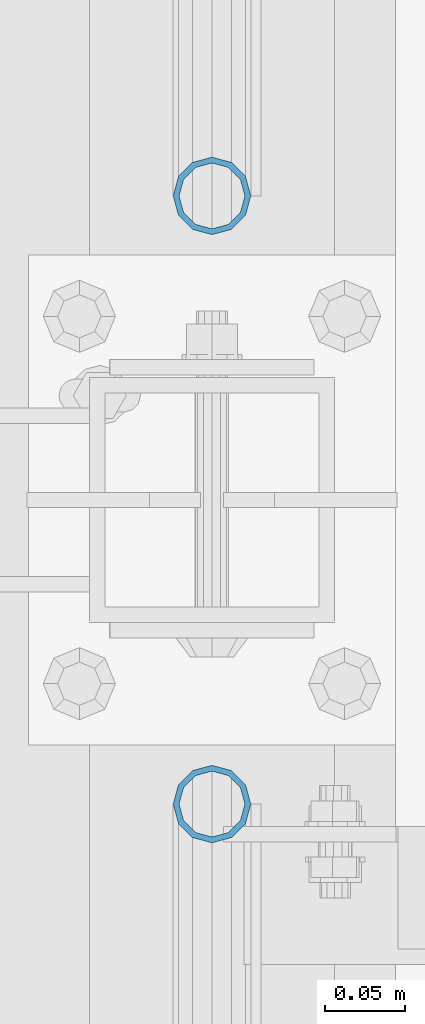
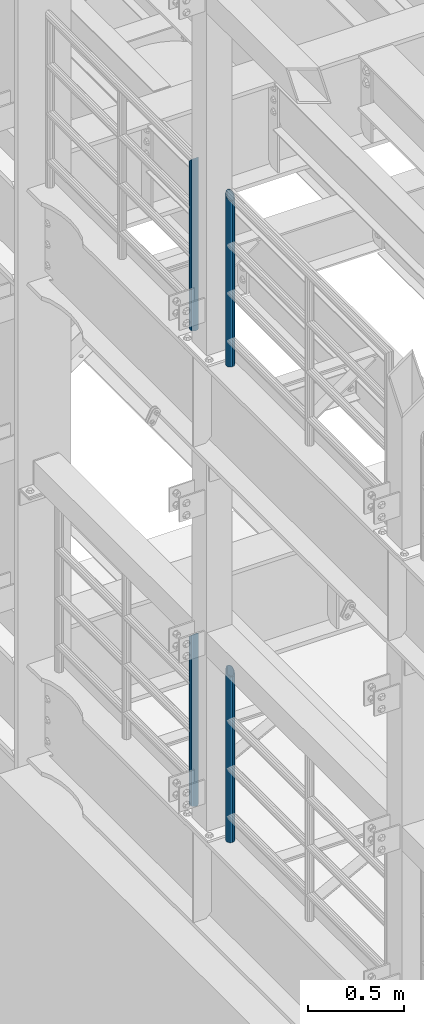
# One storey, part 702 of 1876: 4 columns, 4 elements without a shape of their own.
"""IFC2X3 building model written with IfcOpenShell, lengths in millimetres."""

import ifcopenshell
import ifcopenshell.guid

model = None  # the IFC model being written
_history = None  # IfcOwnerHistory: only IFC2X3 demands one
_inside = {}  # id of a spatial element -> (the spatial element, [elements in it])
_under = {}  # id of a project, library or spatial element -> (it, [spatial elements below it])
_declared = {}  # id of a project -> (the project, [libraries it declares])
_typed = {}  # id of a type object -> (the type object, [elements of that type])
_made_of = {}  # id of a material, layer set ... -> (it, [elements and type objects made of it])


def new_model(schema):
    """Start an empty IFC model of exactly this schema.

    Asked for "IFC4X3", IfcOpenShell would pick the latest addendum, in which some entities
    have other attributes; the version numbers below select the first issue.
    IFC2X3 requires an IfcOwnerHistory on every rooted entity: one is made here for all.
    """
    global model, _history
    if schema == "IFC4X3":
        model = ifcopenshell.file(schema_version=(4, 3, 0, 0))
    else:
        model = ifcopenshell.file(schema=schema)
    _inside.clear()
    _under.clear()
    _declared.clear()
    _typed.clear()
    _made_of.clear()
    _history = None
    if model.schema == "IFC2X3":
        org = make("IfcOrganization", Name="unknown")
        user = make(
            "IfcPersonAndOrganization",
            ThePerson=make("IfcPerson", FamilyName="unknown"),
            TheOrganization=org,
        )
        app = make(
            "IfcApplication",
            ApplicationDeveloper=org,
            Version="unknown",
            ApplicationFullName="unknown",
            ApplicationIdentifier="unknown",
        )
        _history = make(
            "IfcOwnerHistory",
            OwningUser=user,
            OwningApplication=app,
            ChangeAction="ADDED",
            CreationDate=0,
        )
    return model


def make(cls, **values):
    """One entity of the class cls with the attributes given. An attribute that is None is left unset."""
    return model.create_entity(
        cls, **{name: value for name, value in values.items() if value is not None}
    )


def rooted(cls, **values):
    """An entity with a GlobalId (a new one), such as an element, a storey or a relation."""
    return make(cls, GlobalId=ifcopenshell.guid.new(), OwnerHistory=_history, **values)


def si_unit(unit_type, name, prefix=None):
    """IfcSIUnit, for example si_unit("LENGTHUNIT", "METRE", prefix="MILLI")."""
    return make("IfcSIUnit", UnitType=unit_type, Prefix=prefix, Name=name)


def assignment(units):
    """IfcUnitAssignment: the units of a project."""
    return None if units is None else make("IfcUnitAssignment", Units=units)


def point(xyz):
    """IfcCartesianPoint."""
    return None if xyz is None else make("IfcCartesianPoint", Coordinates=xyz)


def direction(xyz):
    """IfcDirection."""
    return None if xyz is None else make("IfcDirection", DirectionRatios=xyz)


def frame(location, z_axis=None, x_axis=None):
    """IfcAxis2Placement3D, a coordinate frame: its origin and axes. An axis left out is left unset."""
    return make(
        "IfcAxis2Placement3D",
        Location=point(location),
        Axis=direction(z_axis),
        RefDirection=direction(x_axis),
    )


def origin_with_axes():
    """The frame at (0, 0, 0) with the z axis (0, 0, 1) and the x axis (1, 0, 0) written out."""
    return frame((0.0, 0.0, 0.0), z_axis=(0.0, 0.0, 1.0), x_axis=(1.0, 0.0, 0.0))


def place(relative_to, where):
    """IfcLocalPlacement: puts the frame where relative to a parent placement (None: the world)."""
    return make(
        "IfcLocalPlacement", PlacementRelTo=relative_to, RelativePlacement=where
    )


def context(
    kind, dimensions, precision=None, world=None, true_north=None, identifier=None
):
    """IfcGeometricRepresentationContext, for example the 3D "Model" context."""
    return make(
        "IfcGeometricRepresentationContext",
        ContextIdentifier=identifier,
        ContextType=kind,
        CoordinateSpaceDimension=dimensions,
        Precision=precision,
        WorldCoordinateSystem=world,
        TrueNorth=true_north,
    )


def subcontext(parent, identifier, kind, view, scale=None):
    """IfcGeometricRepresentationSubContext, for example "Body" below "Model"."""
    return make(
        "IfcGeometricRepresentationSubContext",
        ContextIdentifier=identifier,
        ContextType=kind,
        ParentContext=parent,
        TargetScale=scale,
        TargetView=view,
    )


def project(units=None, contexts=None):
    """IfcProject with its units and contexts."""
    return rooted(
        "IfcProject",
        Name="project",
        RepresentationContexts=contexts,
        UnitsInContext=assignment(units),
    )


def spatial(cls, under=None, at=None, **own):
    """A site, building, storey or space (cls), placed at a placement, below another one or the project."""
    s = rooted(cls, ObjectPlacement=at, **own)
    if under is not None:
        _under.setdefault(under.id(), (under, []))[1].append(s)
    return s


def faces_of(points, faces, orient=None, outer=None):
    """IfcFace entities. A face is a list of loops; a loop is a list of indices into points, from 0.

    orient and outer hold one flag for each loop. By default every Orientation is true, the
    first loop of a face is its IfcFaceOuterBound and the others are IfcFaceBound.
    """
    made = []
    for i, loops in enumerate(faces):
        bounds = []
        for j, loop in enumerate(loops):
            is_outer = j == 0 if outer is None else outer[i][j]
            bounds.append(
                make(
                    "IfcFaceOuterBound" if is_outer else "IfcFaceBound",
                    Bound=make("IfcPolyLoop", Polygon=[points[k] for k in loop]),
                    Orientation=True if orient is None else orient[i][j],
                )
            )
        made.append(make("IfcFace", Bounds=bounds))
    return made


def faceted_brep(points, faces, orient=None, outer=None, voids=None):
    """IfcFacetedBrep: a solid bounded by flat faces; with voids (closed shells), ...WithVoids."""
    shared = [point(p) for p in points]
    hull = make("IfcClosedShell", CfsFaces=faces_of(shared, faces, orient, outer))
    if voids is None:
        return make("IfcFacetedBrep", Outer=hull)
    return make(
        "IfcFacetedBrepWithVoids",
        Outer=hull,
        Voids=[
            make(cls, CfsFaces=faces_of(shared, fs, o, b)) for cls, fs, o, b in voids
        ],
    )


def shape(context_of_items, identifier, shape_type, items):
    """IfcShapeRepresentation: the items that make up one representation, for example the "Body"."""
    return make(
        "IfcShapeRepresentation",
        ContextOfItems=context_of_items,
        RepresentationIdentifier=identifier,
        RepresentationType=shape_type,
        Items=items,
    )


def material(Name=None, Category=None):
    """IfcMaterial."""
    return make("IfcMaterial", Name=Name, Category=Category)


def made_of(thing, what):
    """Note that an element or type object is made of a material, layer set ...; save() writes the relation."""
    if what is not None:
        _made_of.setdefault(what.id(), (what, []))[1].append(thing)
    return thing


def type_object(cls, material=None, **own):
    """A type object (cls), such as IfcWallType, which elements share."""
    return made_of(rooted(cls, **own), material)


def element(
    cls,
    number,
    at=None,
    inside=None,
    cuts=None,
    type_object=None,
    material=None,
    context=None,
    identifier="Body",
    shape_type=None,
    held_by="IfcProductDefinitionShape",
    body=None,
    shapes=None,
    **own,
):
    """One element of the class cls, such as IfcWall. Its Tag is "e" and its number.

    at: its placement. inside: the storey or other place that contains it. cuts: it is an
    opening in that element (IfcRelVoidsElement). A single representation is given by context,
    identifier, shape_type and body (its items); several are given by shapes. held_by: the class
    of the entity that holds the representations. save() writes the other relations.
    """
    e = rooted(cls, Tag="e%d" % number, ObjectPlacement=at, **own)
    if body is not None:
        shapes = [shape(context, identifier, shape_type, body)]
    if shapes is not None:
        e.Representation = make(held_by, Representations=shapes)
    if inside is not None:
        _inside.setdefault(inside.id(), (inside, []))[1].append(e)
    if cuts is not None:
        rooted(
            "IfcRelVoidsElement", RelatingBuildingElement=cuts, RelatedOpeningElement=e
        )
    if type_object is not None:
        _typed.setdefault(type_object.id(), (type_object, []))[1].append(e)
    return made_of(e, material)


def aggregate(whole, parts):
    """IfcRelAggregates: a whole, such as a stair, and the parts it consists of."""
    return rooted("IfcRelAggregates", RelatingObject=whole, RelatedObjects=parts)


def save(model, path):
    """Write the relations noted so far, then the file.

    IfcRelAggregates (storeys below a building ...), IfcRelContainedInSpatialStructure (elements
    in a storey), IfcRelDefinesByType, IfcRelAssociatesMaterial and IfcRelDeclares: one each for
    every whole, place, type object, material and project.
    """
    for whole, parts in _under.values():
        aggregate(whole, parts)
    for where, things in _inside.values():
        rooted(
            "IfcRelContainedInSpatialStructure",
            RelatedElements=things,
            RelatingStructure=where,
        )
    for kind, things in _typed.values():
        rooted("IfcRelDefinesByType", RelatedObjects=things, RelatingType=kind)
    for what, things in _made_of.values():
        rooted("IfcRelAssociatesMaterial", RelatedObjects=things, RelatingMaterial=what)
    for by, libraries in _declared.values():
        rooted("IfcRelDeclares", RelatingContext=by, RelatedDefinitions=libraries)
    model.write(path)


model = new_model("IFC2X3")

# Units and contexts
model_context = context("Model", 3, precision=1e-05, world=origin_with_axes())
body_context = subcontext(model_context, "Body", "Model", "MODEL_VIEW")
ifc_project = project(units=[si_unit("LENGTHUNIT", "METRE", prefix="MILLI"), si_unit("AREAUNIT", "SQUARE_METRE"), si_unit("VOLUMEUNIT", "CUBIC_METRE"), si_unit("MASSUNIT", "GRAM", prefix="KILO"), si_unit("TIMEUNIT", "SECOND"), si_unit("PLANEANGLEUNIT", "RADIAN"), si_unit("SOLIDANGLEUNIT", "STERADIAN"), si_unit("THERMODYNAMICTEMPERATUREUNIT", "DEGREE_CELSIUS"), si_unit("LUMINOUSINTENSITYUNIT", "LUMEN")], contexts=[model_context])

# Site, building, storey
site_placement = place(None, origin_with_axes())
site = spatial("IfcSite", under=ifc_project, at=site_placement, CompositionType="ELEMENT")
building_placement = place(site_placement, origin_with_axes())
building = spatial("IfcBuilding", under=site, at=building_placement, Name="Undefined", CompositionType="ELEMENT")
storey_placement = place(building_placement, origin_with_axes())
storey = spatial("IfcBuildingStorey", under=building, at=storey_placement, Name="Undefined", CompositionType="ELEMENT", Elevation=0.0)

# Assembly, column
assembly_1_placement = place(storey_placement, origin_with_axes())
assembly_1 = element("IfcElementAssembly", 1, at=assembly_1_placement, inside=storey, Name="RAIL", AssemblyPlace="NOTDEFINED", PredefinedType="RIGID_FRAME")
ifc_material = material()
column_type = type_object("IfcColumnType", Name="PIPE1-1/2SCH40", PredefinedType="NOTDEFINED")
column_1_placement = place(assembly_1_placement, frame((-1.81898940354586e-12, 5777.23, 8153.4), z_axis=(0.0, 1.0, 0.0), x_axis=(0.0, 0.0, 1.0)))
column_1 = element("IfcColumn", 2, at=column_1_placement, type_object=column_type, material=ifc_material, Name="POST", ObjectType="PIPE1-1/2SCH40", context=body_context, shape_type="Brep", body=[
    faceted_brep([(0.0, -20.4469999999999, 0.0), (0.0, -17.7076214311803, 10.2235000000001), (1066.1015, -17.7076214311803, 10.2235000000001), (1076.325, -20.4469999999999, 0.0), (0.0, -10.2235000000001, 17.7076214311801), (1058.61737856882, -10.2235000000001, 17.7076214311801), (-1.45519152283669e-11, 0.0, 20.4470000000001), (1055.878, 0.0, 20.4470000000001), (0.0, 10.2235000000001, 17.7076214311801), (1058.61737856882, 10.2235000000001, 17.7076214311801), (0.0, 17.7076214311803, 10.2235000000001), (1066.1015, 17.7076214311803, 10.2235000000001), (0.0, 20.4469999999999, 0.0), (1076.325, 20.4469999999999, 0.0), (0.0, 17.7076214311803, -10.2235000000001), (1086.5485, 17.7076214311803, -10.2235000000001), (0.0, 10.2235000000001, -17.7076214311801), (1094.03262143118, 10.2235000000001, -17.7076214311801), (-1.45519152283669e-11, 0.0, -20.4470000000001), (1096.772, 0.0, -20.4470000000001), (0.0, -10.2235000000001, -17.7076214311801), (1094.03262143118, -10.2235000000001, -17.7076214311801), (0.0, -17.7076214311803, -10.2235000000001), (1086.5485, -17.7076214311803, -10.2235000000001), (0.0, -24.1299999999992, 0.0), (0.0, -20.8971929933184, -12.0649999999996), (1088.39, -20.8971929933184, -12.0649999999996), (1076.325, -24.1300000000001, 0.0), (0.0, -12.0650000000001, -20.8971929933186), (1097.22219299332, -12.0650000000001, -20.8971929933186), (-1.45519152283669e-11, 0.0, -24.130000000001), (1100.455, 0.0, -24.1300000000001), (0.0, 12.0650000000001, -20.8971929933186), (1097.22219299332, 12.0650000000001, -20.8971929933186), (0.0, 20.8971929933184, -12.0649999999996), (1088.39, 20.8971929933184, -12.0649999999996), (0.0, 24.1299999999992, 0.0), (1076.325, 24.1300000000001, 0.0), (0.0, 20.8971929933184, 12.0649999999996), (1064.26, 20.8971929933184, 12.0649999999996), (0.0, 12.0650000000001, 20.8971929933186), (1055.42780700668, 12.0650000000001, 20.8971929933186), (-1.45519152283669e-11, 0.0, 24.130000000001), (1052.195, 0.0, 24.1300000000001), (0.0, -12.0650000000001, 20.8971929933186), (1055.42780700668, -12.0650000000001, 20.8971929933186), (0.0, -20.8971929933184, 12.0649999999996), (1064.26, -20.8971929933184, 12.0649999999996)], [[[0, 1, 2, 3]], [[1, 4, 5, 2]], [[4, 6, 7, 5]], [[6, 8, 9, 7]], [[8, 10, 11, 9]], [[10, 12, 13, 11]], [[12, 14, 15, 13]], [[14, 16, 17, 15]], [[16, 18, 19, 17]], [[18, 20, 21, 19]], [[20, 22, 23, 21]], [[22, 0, 3, 23]], [[24, 25, 26, 27]], [[25, 28, 29, 26]], [[28, 30, 31, 29]], [[30, 32, 33, 31]], [[32, 34, 35, 33]], [[34, 36, 37, 35]], [[36, 38, 39, 37]], [[38, 40, 41, 39]], [[40, 42, 43, 41]], [[42, 44, 45, 43]], [[44, 46, 47, 45]], [[46, 24, 27, 47]], [[29, 31, 33, 35, 37, 39, 41, 43, 45, 47, 27, 26], [5, 7, 9, 11, 13, 15, 17, 19, 21, 23, 3, 2]], [[46, 44, 42, 40, 38, 36, 34, 32, 30, 28, 25, 24], [22, 20, 18, 16, 14, 12, 10, 8, 6, 4, 1, 0]]]),
])
aggregate(assembly_1, [column_1])

assembly_2_placement = place(storey_placement, origin_with_axes())
assembly_2 = element("IfcElementAssembly", 3, at=assembly_2_placement, inside=storey, Name="RAIL", AssemblyPlace="NOTDEFINED", PredefinedType="RIGID_FRAME")
column_2_placement = place(assembly_2_placement, frame((-1.81898940354586e-12, 5398.77, 8153.4), z_axis=(0.0, 1.0, 0.0), x_axis=(0.0, 0.0, 1.0)))
column_2 = element("IfcColumn", 4, at=column_2_placement, type_object=column_type, material=ifc_material, Name="POST", ObjectType="PIPE1-1/2SCH40", context=body_context, shape_type="Brep", body=[
    faceted_brep([(0.0, -20.4469999999999, 0.0), (0.0, -17.7076214311803, 10.2235000000001), (1086.54849999999, -17.7076214311801, 10.2235000000001), (1076.325, -20.4469999999999, 0.0), (0.0, -10.2235000000001, 17.7076214311801), (1094.03262143117, -10.2235000000001, 17.7076214311801), (-1.45519152283669e-11, 0.0, 20.4470000000001), (1096.77199999999, 0.0, 20.4470000000001), (0.0, 10.2235000000001, 17.7076214311801), (1094.03262143117, 10.2235000000001, 17.7076214311801), (0.0, 17.7076214311803, 10.2235000000001), (1086.54849999999, 17.7076214311801, 10.2235000000001), (0.0, 20.4469999999999, 0.0), (1076.325, 20.4469999999999, 0.0), (0.0, 17.7076214311803, -10.2235000000001), (1066.10149999999, 17.7076214311801, -10.2235000000001), (0.0, 10.2235000000001, -17.7076214311801), (1058.61737856881, 10.2235000000001, -17.7076214311801), (-1.45519152283669e-11, 0.0, -20.4470000000001), (1055.87799999999, 0.0, -20.4470000000001), (0.0, -10.2235000000001, -17.7076214311801), (1058.61737856881, -10.2235000000001, -17.7076214311801), (0.0, -17.7076214311803, -10.2235000000001), (1066.10149999999, -17.7076214311801, -10.2235000000001), (0.0, -24.1299999999992, 0.0), (0.0, -20.8971929933184, -12.0649999999996), (1064.25999999999, -20.8971929933186, -12.0649999999996), (1076.325, -24.1300000000001, 0.0), (0.0, -12.0650000000001, -20.8971929933186), (1055.42780700667, -12.0649999999996, -20.8971929933186), (-1.45519152283669e-11, 0.0, -24.130000000001), (1052.19499999999, 0.0, -24.1300000000001), (0.0, 12.0650000000001, -20.8971929933186), (1055.42780700667, 12.0649999999996, -20.8971929933186), (0.0, 20.8971929933184, -12.0649999999996), (1064.25999999999, 20.8971929933186, -12.0649999999996), (0.0, 24.1299999999992, 0.0), (1076.325, 24.1300000000001, 0.0), (0.0, 20.8971929933184, 12.0649999999996), (1088.38999999999, 20.8971929933186, 12.0649999999996), (0.0, 12.0650000000001, 20.8971929933186), (1097.22219299331, 12.0649999999996, 20.8971929933186), (-1.45519152283669e-11, 0.0, 24.130000000001), (1100.45499999999, 0.0, 24.1300000000001), (0.0, -12.0650000000001, 20.8971929933186), (1097.22219299331, -12.0649999999996, 20.8971929933186), (0.0, -20.8971929933184, 12.0649999999996), (1088.38999999999, -20.8971929933186, 12.0649999999996)], [[[0, 1, 2, 3]], [[1, 4, 5, 2]], [[4, 6, 7, 5]], [[6, 8, 9, 7]], [[8, 10, 11, 9]], [[10, 12, 13, 11]], [[12, 14, 15, 13]], [[14, 16, 17, 15]], [[16, 18, 19, 17]], [[18, 20, 21, 19]], [[20, 22, 23, 21]], [[22, 0, 3, 23]], [[24, 25, 26, 27]], [[25, 28, 29, 26]], [[28, 30, 31, 29]], [[30, 32, 33, 31]], [[32, 34, 35, 33]], [[34, 36, 37, 35]], [[36, 38, 39, 37]], [[38, 40, 41, 39]], [[40, 42, 43, 41]], [[42, 44, 45, 43]], [[44, 46, 47, 45]], [[46, 24, 27, 47]], [[29, 31, 33, 35, 37, 39, 41, 43, 45, 47, 27, 26], [5, 7, 9, 11, 13, 15, 17, 19, 21, 23, 3, 2]], [[46, 44, 42, 40, 38, 36, 34, 32, 30, 28, 25, 24], [22, 20, 18, 16, 14, 12, 10, 8, 6, 4, 1, 0]]]),
])
aggregate(assembly_2, [column_2])

assembly_3_placement = place(storey_placement, origin_with_axes())
assembly_3 = element("IfcElementAssembly", 5, at=assembly_3_placement, inside=storey, Name="RAIL", AssemblyPlace="NOTDEFINED", PredefinedType="RIGID_FRAME")
column_3_placement = place(assembly_3_placement, frame((-1.81898940354586e-12, 5777.23, 5130.8), z_axis=(0.0, 1.0, 0.0), x_axis=(0.0, 0.0, 1.0)))
column_3 = element("IfcColumn", 6, at=column_3_placement, type_object=column_type, material=ifc_material, Name="POST", ObjectType="PIPE1-1/2SCH40", context=body_context, shape_type="Brep", body=[
    faceted_brep([(0.0, -20.4469999999999, 0.0), (0.0, -17.7076214311803, 10.2235000000001), (1066.10158618498, -17.7076214311801, 10.2235000000001), (1076.325, -20.4469999999999, 0.0), (0.0, -10.2235000000001, 17.7076214311801), (1058.61752784562, -10.2235000000001, 17.7076214311801), (-1.45519152283669e-11, 0.0, 20.4470000000001), (1055.87817237002, 0.0, 20.4470000000001), (0.0, 10.2235000000001, 17.7076214311801), (1058.61752784562, 10.2235000000001, 17.7076214311801), (0.0, 17.7076214311803, 10.2235000000001), (1066.10158618498, 17.7076214311801, 10.2235000000001), (0.0, 20.4469999999999, 0.0), (1076.325, 20.4469999999999, 0.0), (0.0, 17.7076214311803, -10.2235000000001), (1086.54841381489, 17.7076214311801, -10.2235000000001), (0.0, 10.2235000000001, -17.7076214311801), (1094.03247215425, 10.2235000000001, -17.7076214311801), (-1.45519152283669e-11, 0.0, -20.4470000000001), (1096.77182762985, 0.0, -20.4470000000001), (0.0, -10.2235000000001, -17.7076214311801), (1094.03247215425, -10.2235000000001, -17.7076214311801), (0.0, -17.7076214311803, -10.2235000000001), (1086.54841381489, -17.7076214311801, -10.2235000000001), (0.0, -24.1299999999992, 0.0), (0.0, -20.8971929933184, -12.0649999999996), (1088.38989829088, -20.8971929933186, -12.0649999999996), (1076.325, -24.1300000000001, 0.0), (0.0, -12.0650000000001, -20.8971929933186), (1097.222016828, -12.0649999999996, -20.8971929933186), (-1.45519152283669e-11, 0.0, -24.130000000001), (1100.45479658183, 0.0, -24.1300000000001), (0.0, 12.0650000000001, -20.8971929933186), (1097.222016828, 12.0649999999996, -20.8971929933186), (0.0, 20.8971929933184, -12.0649999999996), (1088.38989829088, 20.8971929933186, -12.0649999999996), (0.0, 24.1299999999992, 0.0), (1076.325, 24.1300000000001, 0.0), (0.0, 20.8971929933184, 12.0649999999996), (1064.26010170542, 20.8971929933186, 12.0650000000001), (0.0, 12.0650000000001, 20.8971929933186), (1055.42798316718, 12.0649999999996, 20.8971929933186), (-1.45519152283669e-11, 0.0, 24.130000000001), (1052.19520341295, 0.0, 24.1300000000001), (0.0, -12.0650000000001, 20.8971929933186), (1055.42798316718, -12.0649999999996, 20.8971929933186), (0.0, -20.8971929933184, 12.0649999999996), (1064.26010170542, -20.8971929933186, 12.0650000000001)], [[[0, 1, 2, 3]], [[1, 4, 5, 2]], [[4, 6, 7, 5]], [[6, 8, 9, 7]], [[8, 10, 11, 9]], [[10, 12, 13, 11]], [[12, 14, 15, 13]], [[14, 16, 17, 15]], [[16, 18, 19, 17]], [[18, 20, 21, 19]], [[20, 22, 23, 21]], [[22, 0, 3, 23]], [[24, 25, 26, 27]], [[25, 28, 29, 26]], [[28, 30, 31, 29]], [[30, 32, 33, 31]], [[32, 34, 35, 33]], [[34, 36, 37, 35]], [[36, 38, 39, 37]], [[38, 40, 41, 39]], [[40, 42, 43, 41]], [[42, 44, 45, 43]], [[44, 46, 47, 45]], [[46, 24, 27, 47]], [[29, 31, 33, 35, 37, 39, 41, 43, 45, 47, 27, 26], [5, 7, 9, 11, 13, 15, 17, 19, 21, 23, 3, 2]], [[46, 44, 42, 40, 38, 36, 34, 32, 30, 28, 25, 24], [22, 20, 18, 16, 14, 12, 10, 8, 6, 4, 1, 0]]]),
])
aggregate(assembly_3, [column_3])

assembly_4_placement = place(storey_placement, origin_with_axes())
assembly_4 = element("IfcElementAssembly", 7, at=assembly_4_placement, inside=storey, Name="RAIL", AssemblyPlace="NOTDEFINED", PredefinedType="RIGID_FRAME")
column_4_placement = place(assembly_4_placement, frame((-1.81898940354586e-12, 5398.77, 5130.8), z_axis=(0.0, 1.0, 0.0), x_axis=(0.0, 0.0, 1.0)))
column_4 = element("IfcColumn", 8, at=column_4_placement, type_object=column_type, material=ifc_material, Name="POST", ObjectType="PIPE1-1/2SCH40", context=body_context, shape_type="Brep", body=[
    faceted_brep([(0.0, -20.4469999999999, 0.0), (0.0, -17.7076214311803, 10.2235000000001), (1086.54849999999, -17.7076214311801, 10.2235000000001), (1076.325, -20.4469999999999, 0.0), (0.0, -10.2235000000001, 17.7076214311801), (1094.03262143117, -10.2235000000001, 17.7076214311801), (-1.45519152283669e-11, 0.0, 20.4470000000001), (1096.77199999999, 0.0, 20.4470000000001), (0.0, 10.2235000000001, 17.7076214311801), (1094.03262143117, 10.2235000000001, 17.7076214311801), (0.0, 17.7076214311803, 10.2235000000001), (1086.54849999999, 17.7076214311801, 10.2235000000001), (0.0, 20.4469999999999, 0.0), (1076.325, 20.4469999999999, 0.0), (0.0, 17.7076214311803, -10.2235000000001), (1066.10149999999, 17.7076214311801, -10.2235000000001), (0.0, 10.2235000000001, -17.7076214311801), (1058.61737856881, 10.2235000000001, -17.7076214311801), (-1.45519152283669e-11, 0.0, -20.4470000000001), (1055.87799999999, 0.0, -20.4470000000001), (0.0, -10.2235000000001, -17.7076214311801), (1058.61737856881, -10.2235000000001, -17.7076214311801), (0.0, -17.7076214311803, -10.2235000000001), (1066.10149999999, -17.7076214311801, -10.2235000000001), (0.0, -24.1299999999992, 0.0), (0.0, -20.8971929933184, -12.0649999999996), (1064.25999999999, -20.8971929933186, -12.0649999999996), (1076.325, -24.1300000000001, 0.0), (0.0, -12.0650000000001, -20.8971929933186), (1055.42780700667, -12.0649999999996, -20.8971929933186), (-1.45519152283669e-11, 0.0, -24.130000000001), (1052.19499999999, 0.0, -24.1300000000001), (0.0, 12.0650000000001, -20.8971929933186), (1055.42780700667, 12.0649999999996, -20.8971929933186), (0.0, 20.8971929933184, -12.0649999999996), (1064.25999999999, 20.8971929933186, -12.0649999999996), (0.0, 24.1299999999992, 0.0), (1076.325, 24.1300000000001, 0.0), (0.0, 20.8971929933184, 12.0649999999996), (1088.38999999999, 20.8971929933186, 12.0649999999996), (0.0, 12.0650000000001, 20.8971929933186), (1097.22219299331, 12.0649999999996, 20.8971929933186), (-1.45519152283669e-11, 0.0, 24.130000000001), (1100.45499999999, 0.0, 24.1300000000001), (0.0, -12.0650000000001, 20.8971929933186), (1097.22219299331, -12.0649999999996, 20.8971929933186), (0.0, -20.8971929933184, 12.0649999999996), (1088.38999999999, -20.8971929933186, 12.0649999999996)], [[[0, 1, 2, 3]], [[1, 4, 5, 2]], [[4, 6, 7, 5]], [[6, 8, 9, 7]], [[8, 10, 11, 9]], [[10, 12, 13, 11]], [[12, 14, 15, 13]], [[14, 16, 17, 15]], [[16, 18, 19, 17]], [[18, 20, 21, 19]], [[20, 22, 23, 21]], [[22, 0, 3, 23]], [[24, 25, 26, 27]], [[25, 28, 29, 26]], [[28, 30, 31, 29]], [[30, 32, 33, 31]], [[32, 34, 35, 33]], [[34, 36, 37, 35]], [[36, 38, 39, 37]], [[38, 40, 41, 39]], [[40, 42, 43, 41]], [[42, 44, 45, 43]], [[44, 46, 47, 45]], [[46, 24, 27, 47]], [[29, 31, 33, 35, 37, 39, 41, 43, 45, 47, 27, 26], [5, 7, 9, 11, 13, 15, 17, 19, 21, 23, 3, 2]], [[46, 44, 42, 40, 38, 36, 34, 32, 30, 28, 25, 24], [22, 20, 18, 16, 14, 12, 10, 8, 6, 4, 1, 0]]]),
])
aggregate(assembly_4, [column_4])

save(model, "model.ifc")
